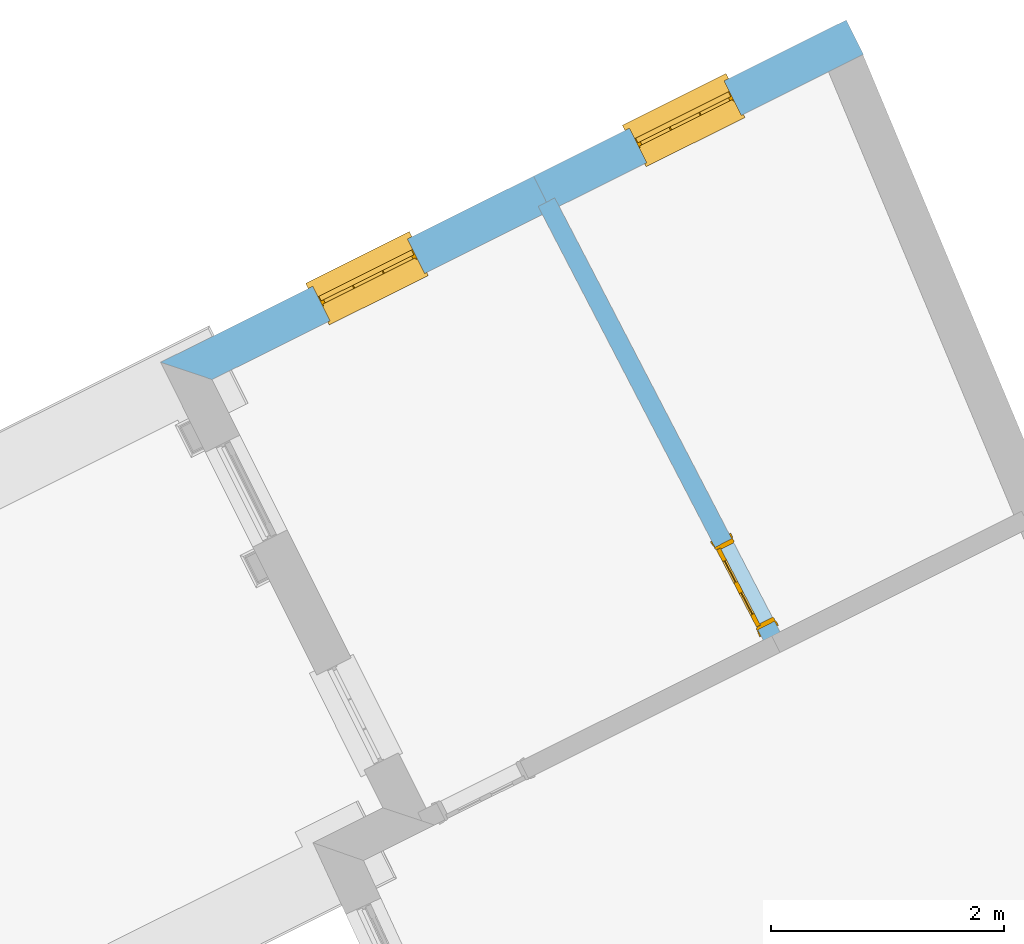
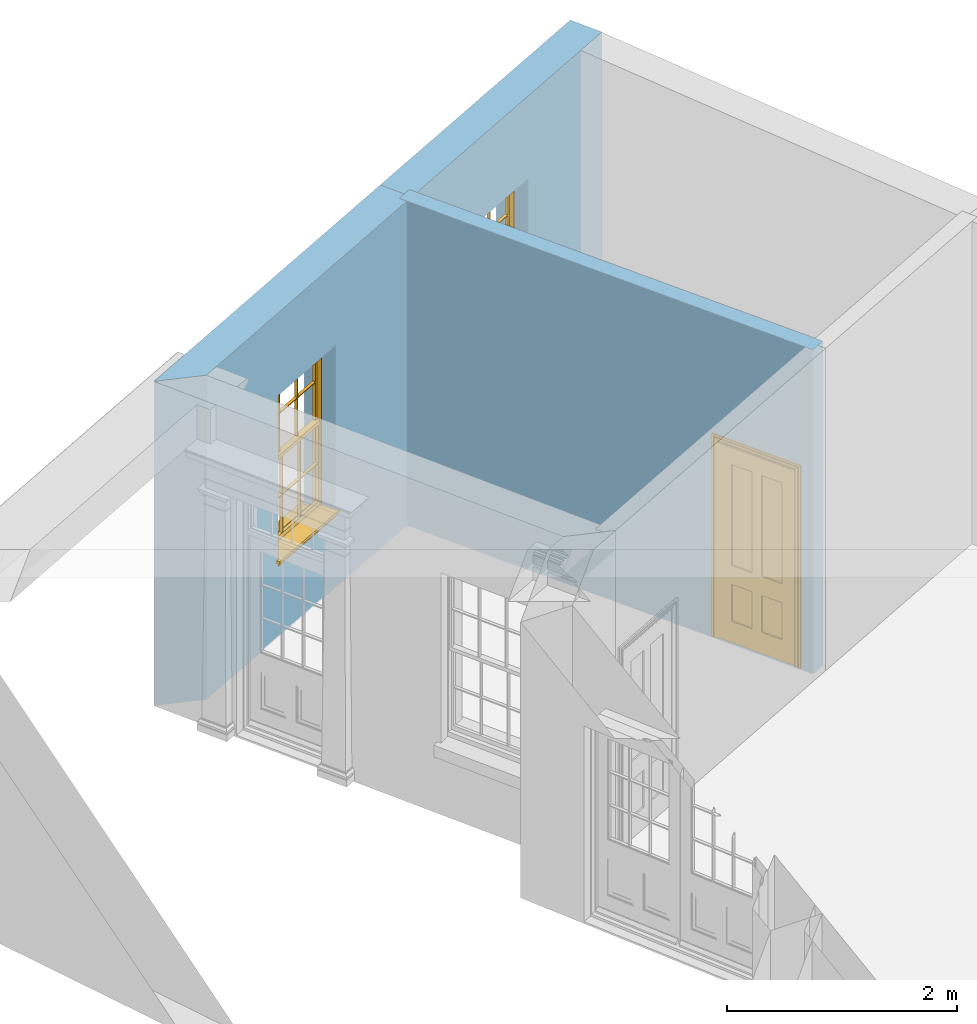
# One storey, part 9 of 10: 2 windows, 1 door, 3 openings, plus 3 elements that do not belong to this part.
"""IFC2X3 building model written with IfcOpenShell, lengths in metres."""

from ifc_helpers import new_model, si_unit, frame, origin, place, context, subcontext, project, spatial, polyline, outline, extrude, faceted_brep, material, layer, layer_set, layer_usage, element, fill, save


model = new_model("IFC2X3")

# Units and contexts
model_context = context("Model", 3, world=origin())
body_context = subcontext(model_context, "Body", "Model", "MODEL_VIEW")
ifc_project = project(units=[si_unit("PLANEANGLEUNIT", "RADIAN"), si_unit("MASSUNIT", "GRAM", prefix="KILO"), si_unit("FORCEUNIT", "NEWTON", prefix="KILO"), si_unit("LENGTHUNIT", "METRE")], contexts=[model_context])

# Site, building, storey
site_placement = place(None, origin())
site = spatial("IfcSite", under=ifc_project, at=site_placement, CompositionType="ELEMENT")
building_placement = place(None, origin())
building = spatial("IfcBuilding", under=site, at=building_placement, Name="Building plot-8", CompositionType="ELEMENT")
storey_placement = place(None, origin())
storey = spatial("IfcBuildingStorey", under=building, at=storey_placement, Name="Floor 0", CompositionType="ELEMENT", Elevation=0.0)

# Wall, opening, window
ifc_material_1 = material(Name="Masonry")
ifc_layer_1 = layer(ifc_material_1, 0.33, ventilated=False)
ifc_layer_set_1 = layer_set([ifc_layer_1], Name="My Wall")
ifc_layer_usage_1 = layer_usage(ifc_layer_set_1, "AXIS2", "NEGATIVE", 0.08)
wall_1_placement = place(storey_placement, origin())
wall_1 = element("IfcWallStandardCase", 1, at=wall_1_placement, inside=storey, material=ifc_layer_usage_1, Name="exterior", context=body_context, shape_type="SweptSolid", body=[
    extrude(outline(polyline([(28.1976396877446, 19.9353489269842), (28.0502378466283, 20.230599155156), (25.3643689149095, 18.889695786567), (25.5117707560258, 18.5944455583952), (28.1976396877446, 19.9353489269842)])), origin(), (0.0, 0.0, 1.0), 3.45),
])
opening_1_placement = place(storey_placement, frame((0.0, 0.0, 0.75)))
opening_1 = element("IfcOpeningElement", 2, at=opening_1_placement, cuts=wall_1, Name="Opening", ObjectType="Opening", context=body_context, shape_type="SweptSolid", body=[
    extrude(outline(polyline([(27.0025536089408, 19.7075493119778), (26.1883787373153, 19.3010775682935), (26.3357805784316, 19.0058273401217), (27.149955450057, 19.4122990838059), (27.0025536089408, 19.7075493119778)])), origin(), (0.0, 0.0, 1.0), 1.82),
])
window_1_placement = place(storey_placement, frame((27.1142216703925, 19.4838748966961, 0.75), z_axis=(0.0, 0.0, 1.0), x_axis=(-0.814174871625433, -0.406471743684243, 0.0)))
window_1 = element("IfcWindow", 3, at=window_1_placement, inside=storey, Name="toilet street window", OverallHeight=1.82, OverallWidth=0.91, context=body_context, shape_type="Brep", held_by="IfcProductRepresentation", body=[
    faceted_brep([(0.033125, -0.105, 0.975209), (0.01, -0.105, 0.975209), (0.033125, -0.105, 1.376042), (0.876875, -0.105, 0.975209), (0.876875, -0.105, 1.376042), (0.9, -0.105, 0.975209), (0.876875, -0.105, 1.386042), (0.876875, -0.105, 1.786875), (0.9, -0.105, 1.81), (0.033125, -0.105, 1.786875), (0.033125, -0.105, 1.386042), (0.01, -0.105, 1.81), (0.876875, -0.135, 1.376042), (0.876875, -0.135, 0.975209), (0.9, -0.135, 0.937083), (0.033125, -0.135, 1.786875), (0.01, -0.135, 1.81), (0.033125, -0.135, 1.386042), (0.01, -0.135, 0.937083), (0.033125, -0.135, 0.975209), (0.033125, -0.135, 1.376042), (0.876875, -0.135, 1.786875), (0.876875, -0.135, 1.386042), (0.9, -0.135, 1.81), (0.033125, -0.105, 0.937083), (0.01, -0.105, 0.937083), (0.033125, -0.105, 0.53625), (0.876875, -0.105, 0.937083), (0.876875, -0.105, 0.53625), (0.9, -0.105, 0.937083), (0.876875, -0.105, 0.52625), (0.876875, -0.105, 0.125417), (0.9, -0.105, 0.077167), (0.033125, -0.105, 0.125417), (0.033125, -0.105, 0.52625), (0.01, -0.105, 0.077167), (-0.0425, -0.25, 0.01), (-0.0425, -0.3, 0.001667), (0.0, -0.25, 0.01), (0.9525, -0.25, 0.01), (0.91, -0.25, 0.01), (0.9525, -0.3, 0.001667), (-0.02, 0.08, 0.077167), (0.0, 0.08, 0.077167), (-0.02, 0.11, 0.077167), (0.0, -0.06, 0.077167), (0.01, -0.06, 0.077167), (0.91, -0.06, 0.077167), (0.91, 0.08, 0.077167), (0.9, -0.06, 0.077167), (0.93, 0.08, 0.077167), (0.93, 0.11, 0.077167), (0.01, -0.075, 0.975209), (0.9, -0.075, 0.975209), (0.876875, -0.075, 0.125417), (0.876875, -0.075, 0.52625), (0.9, -0.075, 0.077167), (0.876875, -0.075, 0.53625), (0.876875, -0.075, 0.937083), (0.033125, -0.075, 0.125417), (0.01, -0.075, 0.077167), (0.033125, -0.075, 0.52625), (0.033125, -0.075, 0.937083), (0.033125, -0.075, 0.53625), (-0.02, 0.08, 0.052167), (-0.02, 0.11, 0.052167), (0.93, 0.11, 0.052167), (0.93, 0.08, 0.052167), (0.91, 0.08, 0.052167), (0.0, 0.08, 0.052167), (0.91, -0.15, 0.026667), (0.0, -0.15, 0.026667), (-0.0425, -0.3, -0.123333), (0.9525, -0.3, -0.123333), (-0.0425, -0.25, -0.123333), (0.9525, -0.25, -0.123333), (0.01, -0.06, 1.81), (0.9, -0.06, 1.81), (0.0, -0.06, 1.82), (0.91, -0.06, 1.82), (0.01, -0.15, 0.077167), (0.9, -0.15, 0.077167), (0.592292, -0.105, 0.125417), (0.592292, -0.075, 0.125417), (0.317708, -0.075, 0.125417), (0.317708, -0.105, 0.125417), (0.592292, -0.105, 0.53625), (0.317708, -0.105, 0.53625), (0.317708, -0.105, 0.52625), (0.592292, -0.105, 0.52625), (0.592292, -0.075, 0.53625), (0.317708, -0.075, 0.53625), (0.592292, -0.135, 1.386042), (0.592292, -0.105, 1.386042), (0.317708, -0.105, 1.386042), (0.317708, -0.135, 1.386042), (0.317708, -0.135, 1.376042), (0.592292, -0.135, 1.376042), (0.317708, -0.105, 1.376042), (0.592292, -0.105, 1.376042), (0.602292, -0.135, 1.376042), (0.592292, -0.135, 0.975209), (0.602292, -0.135, 0.975209), (0.602292, -0.105, 0.975209), (0.592292, -0.105, 0.975209), (0.602292, -0.105, 1.376042), (0.602292, -0.075, 0.53625), (0.602292, -0.105, 0.53625), (0.317708, -0.075, 0.52625), (0.307708, -0.075, 0.125417), (0.307708, -0.075, 0.52625), (0.602292, -0.075, 0.52625), (0.602292, -0.075, 0.125417), (0.592292, -0.075, 0.52625), (0.307708, -0.075, 0.53625), (0.317708, -0.075, 0.937083), (0.307708, -0.075, 0.937083), (0.602292, -0.075, 0.937083), (0.592292, -0.075, 0.937083), (0.307708, -0.105, 0.52625), (0.307708, -0.105, 0.125417), (0.307708, -0.105, 0.53625), (0.307708, -0.105, 0.937083), (0.592292, -0.105, 0.937083), (0.317708, -0.105, 0.937083), (0.602292, -0.105, 0.937083), (0.602292, -0.105, 0.52625), (0.602292, -0.105, 0.125417), (0.307708, -0.135, 1.386042), (0.307708, -0.135, 1.376042), (0.307708, -0.135, 0.975209), (0.317708, -0.135, 0.975209), (0.317708, -0.135, 1.786875), (0.307708, -0.135, 1.786875), (0.602292, -0.135, 1.786875), (0.592292, -0.135, 1.786875), (0.602292, -0.135, 1.386042), (0.602292, -0.105, 1.386042), (0.307708, -0.105, 1.386042), (0.307708, -0.105, 1.786875), (0.317708, -0.105, 1.786875), (0.592292, -0.105, 1.786875), (0.602292, -0.105, 1.786875), (0.307708, -0.105, 1.376042), (0.317708, -0.105, 0.975209), (0.307708, -0.105, 0.975209), (0.91, -0.15, 1.82), (0.9, -0.15, 1.81), (0.01, -0.15, 1.81), (0.0, -0.15, 1.82), (0.91, -0.25, 0.0), (0.0, -0.25, 0.0), (0.91, 0.08, 0.0), (0.0, 0.08, 0.0)], [[[0, 1, 2]], [[3, 4, 5]], [[6, 7, 8]], [[9, 10, 11]], [[12, 13, 14]], [[15, 16, 17]], [[18, 19, 20]], [[21, 22, 23]], [[24, 25, 26]], [[27, 28, 29]], [[30, 31, 32]], [[33, 34, 35]], [[14, 27, 29]], [[25, 24, 18]], [[36, 37, 38]], [[39, 40, 41]], [[42, 43, 44]], [[45, 46, 43]], [[47, 48, 49]], [[50, 51, 48]], [[1, 0, 52]], [[5, 53, 3]], [[54, 55, 56]], [[57, 58, 53]], [[59, 60, 61]], [[62, 63, 52]], [[48, 43, 46, 49]], [[51, 44, 43, 48]], [[64, 42, 44, 65]], [[65, 44, 51, 66]], [[66, 51, 50, 67]], [[65, 66, 68, 69]], [[60, 56, 49, 46]], [[70, 71, 38, 40]], [[37, 41, 40, 38]], [[37, 72, 73, 41]], [[74, 75, 73, 72]], [[8, 11, 76, 77]], [[76, 78, 79, 77]], [[32, 35, 80, 81]], [[81, 80, 71, 70]], [[82, 83, 84, 85]], [[86, 87, 88, 89]], [[86, 90, 91, 87]], [[92, 93, 94, 95]], [[92, 95, 96, 97]], [[96, 98, 99, 97]], [[100, 97, 101, 102]], [[103, 104, 99, 105]], [[97, 99, 104, 101]], [[102, 103, 105, 100]], [[28, 57, 106, 107]], [[108, 84, 109, 110]], [[111, 112, 83, 113]], [[114, 110, 61, 63]], [[90, 113, 108, 91]], [[115, 91, 114, 116]], [[117, 106, 90, 118]], [[111, 106, 57, 55]], [[119, 110, 109, 120]], [[34, 61, 110, 119]], [[89, 113, 83, 82]], [[88, 108, 113, 89]], [[85, 84, 108, 88]], [[121, 114, 63, 26]], [[122, 116, 114, 121]], [[123, 118, 90, 86]], [[87, 91, 115, 124]], [[107, 106, 117, 125]], [[126, 111, 55, 30]], [[127, 112, 111, 126]], [[126, 30, 28, 107]], [[88, 119, 120, 85]], [[126, 89, 82, 127]], [[125, 123, 86, 107]], [[121, 26, 34, 119]], [[124, 122, 121, 87]], [[128, 17, 20, 129]], [[96, 129, 130, 131]], [[132, 133, 128, 95]], [[134, 135, 92, 136]], [[100, 12, 22, 136]], [[137, 6, 4, 105]], [[94, 138, 139, 140]], [[137, 93, 141, 142]], [[99, 98, 94, 93]], [[143, 2, 10, 138]], [[144, 145, 143, 98]], [[129, 143, 145, 130]], [[20, 2, 143, 129]], [[131, 144, 98, 96]], [[128, 138, 10, 17]], [[133, 139, 138, 128]], [[135, 141, 93, 92]], [[95, 94, 140, 132]], [[22, 6, 137, 136]], [[136, 137, 142, 134]], [[100, 105, 4, 12]], [[107, 86, 89, 126]], [[106, 111, 113, 90]], [[91, 108, 110, 114]], [[87, 121, 119, 88]], [[97, 100, 136, 92]], [[129, 96, 95, 128]], [[98, 143, 138, 94]], [[105, 99, 93, 137]], [[131, 101, 104, 144]], [[124, 115, 118, 123]], [[132, 140, 141, 135]], [[120, 109, 59, 33]], [[15, 9, 139, 133]], [[134, 142, 7, 21]], [[31, 54, 112, 127]], [[36, 74, 72, 37]], [[39, 41, 73, 75]], [[18, 14, 101, 131]], [[23, 16, 132, 135]], [[83, 56, 60, 84]], [[52, 53, 118, 115]], [[53, 52, 144, 104]], [[11, 8, 141, 140]], [[14, 18, 124, 123]], [[2, 1, 11, 10]], [[8, 5, 4, 6]], [[57, 53, 56, 55]], [[60, 52, 63, 61]], [[26, 25, 35, 34]], [[32, 29, 28, 30]], [[14, 23, 22, 12]], [[18, 20, 17, 16]], [[19, 0, 2, 20]], [[17, 10, 9, 15]], [[12, 4, 3, 13]], [[21, 7, 6, 22]], [[27, 58, 57, 28]], [[30, 55, 54, 31]], [[33, 59, 61, 34]], [[26, 63, 62, 24]], [[5, 8, 77, 53]], [[76, 11, 1, 52]], [[46, 45, 78, 76]], [[49, 77, 79, 47]], [[70, 146, 147, 81]], [[71, 80, 148, 149]], [[19, 130, 145, 0]], [[102, 13, 3, 103]], [[116, 122, 24, 62]], [[29, 32, 81, 14]], [[80, 35, 25, 18]], [[60, 46, 76, 52]], [[77, 49, 56, 53]], [[23, 14, 81, 147]], [[16, 148, 80, 18]], [[35, 85, 120]], [[120, 33, 35]], [[127, 82, 32]], [[32, 31, 127]], [[32, 82, 85, 35]], [[102, 101, 14]], [[14, 13, 102]], [[18, 131, 130]], [[130, 19, 18]], [[134, 21, 23]], [[23, 135, 134]], [[16, 15, 133]], [[133, 132, 16]], [[11, 140, 139]], [[139, 9, 11]], [[142, 141, 8]], [[8, 7, 142]], [[23, 147, 148, 16]], [[146, 149, 148, 147]], [[52, 115, 116]], [[116, 62, 52]], [[118, 53, 117]], [[58, 117, 53]], [[27, 125, 117, 58]], [[56, 83, 112]], [[112, 54, 56]], [[109, 84, 60]], [[60, 59, 109]], [[125, 27, 14]], [[14, 123, 125]], [[122, 124, 18]], [[18, 24, 122]], [[145, 144, 52]], [[52, 0, 145]], [[103, 3, 53]], [[53, 104, 103]], [[79, 78, 149, 146]], [[78, 45, 71, 149]], [[146, 70, 47, 79]], [[150, 75, 74, 151]], [[68, 66, 67]], [[48, 68, 67, 50]], [[69, 64, 65]], [[42, 64, 69, 43]], [[69, 68, 152, 153]], [[70, 68, 48, 47]], [[150, 152, 68, 70]], [[43, 69, 71, 45]], [[69, 153, 151, 71]], [[152, 150, 151, 153]], [[38, 151, 74, 36]], [[71, 151, 38]], [[39, 75, 150, 40]], [[40, 150, 70]]]),
])
fill(opening_1, window_1)

wall_2_placement = place(storey_placement, origin())
wall_2 = element("IfcWallStandardCase", 4, at=wall_2_placement, inside=storey, material=ifc_layer_usage_1, Name="exterior", context=body_context, shape_type="SweptSolid", body=[
    extrude(outline(polyline([(25.5117707560258, 18.5944455583952), (25.3643689149095, 18.889695786567), (22.162338538902, 17.2911020254168), (22.6049906081901, 17.1432536383612), (25.5117707560258, 18.5944455583952)])), origin(), (0.0, 0.0, 1.0), 3.45),
])
opening_2_placement = place(storey_placement, frame((0.0, 0.0, 0.75)))
opening_2 = element("IfcOpeningElement", 5, at=opening_2_placement, cuts=wall_2, Name="Opening", ObjectType="Opening", context=body_context, shape_type="SweptSolid", body=[
    extrude(outline(polyline([(24.2822783703593, 18.3494688085599), (23.4681034987339, 17.9429970648756), (23.6155053398501, 17.6477468367038), (24.4296802114756, 18.054218580388), (24.2822783703593, 18.3494688085599)])), origin(), (0.0, 0.0, 1.0), 1.82),
])
window_2_placement = place(storey_placement, frame((24.393946431811, 18.1257943932782, 0.75), z_axis=(0.0, 0.0, 1.0), x_axis=(-0.814174871625433, -0.406471743684246, 0.0)))
window_2 = element("IfcWindow", 6, at=window_2_placement, inside=storey, Name="circulation street window", OverallHeight=1.82, OverallWidth=0.91, context=body_context, shape_type="Brep", held_by="IfcProductRepresentation", body=[
    faceted_brep([(0.033125, -0.105, 0.975209), (0.01, -0.105, 0.975209), (0.033125, -0.105, 1.376042), (0.876875, -0.105, 0.975209), (0.876875, -0.105, 1.376042), (0.9, -0.105, 0.975209), (0.876875, -0.105, 1.386042), (0.876875, -0.105, 1.786875), (0.9, -0.105, 1.81), (0.033125, -0.105, 1.786875), (0.033125, -0.105, 1.386042), (0.01, -0.105, 1.81), (0.876875, -0.135, 1.376042), (0.876875, -0.135, 0.975209), (0.9, -0.135, 0.937083), (0.033125, -0.135, 1.786875), (0.01, -0.135, 1.81), (0.033125, -0.135, 1.386042), (0.01, -0.135, 0.937083), (0.033125, -0.135, 0.975209), (0.033125, -0.135, 1.376042), (0.876875, -0.135, 1.786875), (0.876875, -0.135, 1.386042), (0.9, -0.135, 1.81), (0.033125, -0.105, 0.937083), (0.01, -0.105, 0.937083), (0.033125, -0.105, 0.53625), (0.876875, -0.105, 0.937083), (0.876875, -0.105, 0.53625), (0.9, -0.105, 0.937083), (0.876875, -0.105, 0.52625), (0.876875, -0.105, 0.125417), (0.9, -0.105, 0.077167), (0.033125, -0.105, 0.125417), (0.033125, -0.105, 0.52625), (0.01, -0.105, 0.077167), (-0.0425, -0.25, 0.01), (-0.0425, -0.3, 0.001667), (0.0, -0.25, 0.01), (0.9525, -0.25, 0.01), (0.91, -0.25, 0.01), (0.9525, -0.3, 0.001667), (-0.02, 0.08, 0.077167), (0.0, 0.08, 0.077167), (-0.02, 0.11, 0.077167), (0.0, -0.06, 0.077167), (0.01, -0.06, 0.077167), (0.91, -0.06, 0.077167), (0.91, 0.08, 0.077167), (0.9, -0.06, 0.077167), (0.93, 0.08, 0.077167), (0.93, 0.11, 0.077167), (0.01, -0.075, 0.975209), (0.9, -0.075, 0.975209), (0.876875, -0.075, 0.125417), (0.876875, -0.075, 0.52625), (0.9, -0.075, 0.077167), (0.876875, -0.075, 0.53625), (0.876875, -0.075, 0.937083), (0.033125, -0.075, 0.125417), (0.01, -0.075, 0.077167), (0.033125, -0.075, 0.52625), (0.033125, -0.075, 0.937083), (0.033125, -0.075, 0.53625), (-0.02, 0.08, 0.052167), (-0.02, 0.11, 0.052167), (0.93, 0.11, 0.052167), (0.93, 0.08, 0.052167), (0.91, 0.08, 0.052167), (0.0, 0.08, 0.052167), (0.91, -0.15, 0.026667), (0.0, -0.15, 0.026667), (-0.0425, -0.3, -0.123333), (0.9525, -0.3, -0.123333), (-0.0425, -0.25, -0.123333), (0.9525, -0.25, -0.123333), (0.01, -0.06, 1.81), (0.9, -0.06, 1.81), (0.0, -0.06, 1.82), (0.91, -0.06, 1.82), (0.01, -0.15, 0.077167), (0.9, -0.15, 0.077167), (0.592292, -0.105, 0.125417), (0.592292, -0.075, 0.125417), (0.317708, -0.075, 0.125417), (0.317708, -0.105, 0.125417), (0.592292, -0.105, 0.53625), (0.317708, -0.105, 0.53625), (0.317708, -0.105, 0.52625), (0.592292, -0.105, 0.52625), (0.592292, -0.075, 0.53625), (0.317708, -0.075, 0.53625), (0.592292, -0.135, 1.386042), (0.592292, -0.105, 1.386042), (0.317708, -0.105, 1.386042), (0.317708, -0.135, 1.386042), (0.317708, -0.135, 1.376042), (0.592292, -0.135, 1.376042), (0.317708, -0.105, 1.376042), (0.592292, -0.105, 1.376042), (0.602292, -0.135, 1.376042), (0.592292, -0.135, 0.975209), (0.602292, -0.135, 0.975209), (0.602292, -0.105, 0.975209), (0.592292, -0.105, 0.975209), (0.602292, -0.105, 1.376042), (0.602292, -0.075, 0.53625), (0.602292, -0.105, 0.53625), (0.317708, -0.075, 0.52625), (0.307708, -0.075, 0.125417), (0.307708, -0.075, 0.52625), (0.602292, -0.075, 0.52625), (0.602292, -0.075, 0.125417), (0.592292, -0.075, 0.52625), (0.307708, -0.075, 0.53625), (0.317708, -0.075, 0.937083), (0.307708, -0.075, 0.937083), (0.602292, -0.075, 0.937083), (0.592292, -0.075, 0.937083), (0.307708, -0.105, 0.52625), (0.307708, -0.105, 0.125417), (0.307708, -0.105, 0.53625), (0.307708, -0.105, 0.937083), (0.592292, -0.105, 0.937083), (0.317708, -0.105, 0.937083), (0.602292, -0.105, 0.937083), (0.602292, -0.105, 0.52625), (0.602292, -0.105, 0.125417), (0.307708, -0.135, 1.386042), (0.307708, -0.135, 1.376042), (0.307708, -0.135, 0.975209), (0.317708, -0.135, 0.975209), (0.317708, -0.135, 1.786875), (0.307708, -0.135, 1.786875), (0.602292, -0.135, 1.786875), (0.592292, -0.135, 1.786875), (0.602292, -0.135, 1.386042), (0.602292, -0.105, 1.386042), (0.307708, -0.105, 1.386042), (0.307708, -0.105, 1.786875), (0.317708, -0.105, 1.786875), (0.592292, -0.105, 1.786875), (0.602292, -0.105, 1.786875), (0.307708, -0.105, 1.376042), (0.317708, -0.105, 0.975209), (0.307708, -0.105, 0.975209), (0.91, -0.15, 1.82), (0.9, -0.15, 1.81), (0.01, -0.15, 1.81), (0.0, -0.15, 1.82), (0.91, -0.25, 0.0), (0.0, -0.25, 0.0), (0.91, 0.08, 0.0), (0.0, 0.08, 0.0)], [[[0, 1, 2]], [[3, 4, 5]], [[6, 7, 8]], [[9, 10, 11]], [[12, 13, 14]], [[15, 16, 17]], [[18, 19, 20]], [[21, 22, 23]], [[24, 25, 26]], [[27, 28, 29]], [[30, 31, 32]], [[33, 34, 35]], [[14, 27, 29]], [[25, 24, 18]], [[36, 37, 38]], [[39, 40, 41]], [[42, 43, 44]], [[45, 46, 43]], [[47, 48, 49]], [[50, 51, 48]], [[1, 0, 52]], [[5, 53, 3]], [[54, 55, 56]], [[57, 58, 53]], [[59, 60, 61]], [[62, 63, 52]], [[48, 43, 46, 49]], [[51, 44, 43, 48]], [[64, 42, 44, 65]], [[65, 44, 51, 66]], [[66, 51, 50, 67]], [[65, 66, 68, 69]], [[60, 56, 49, 46]], [[70, 71, 38, 40]], [[37, 41, 40, 38]], [[37, 72, 73, 41]], [[74, 75, 73, 72]], [[8, 11, 76, 77]], [[76, 78, 79, 77]], [[32, 35, 80, 81]], [[81, 80, 71, 70]], [[82, 83, 84, 85]], [[86, 87, 88, 89]], [[86, 90, 91, 87]], [[92, 93, 94, 95]], [[92, 95, 96, 97]], [[96, 98, 99, 97]], [[100, 97, 101, 102]], [[103, 104, 99, 105]], [[97, 99, 104, 101]], [[102, 103, 105, 100]], [[28, 57, 106, 107]], [[108, 84, 109, 110]], [[111, 112, 83, 113]], [[114, 110, 61, 63]], [[90, 113, 108, 91]], [[115, 91, 114, 116]], [[117, 106, 90, 118]], [[111, 106, 57, 55]], [[119, 110, 109, 120]], [[34, 61, 110, 119]], [[89, 113, 83, 82]], [[88, 108, 113, 89]], [[85, 84, 108, 88]], [[121, 114, 63, 26]], [[122, 116, 114, 121]], [[123, 118, 90, 86]], [[87, 91, 115, 124]], [[107, 106, 117, 125]], [[126, 111, 55, 30]], [[127, 112, 111, 126]], [[126, 30, 28, 107]], [[88, 119, 120, 85]], [[126, 89, 82, 127]], [[125, 123, 86, 107]], [[121, 26, 34, 119]], [[124, 122, 121, 87]], [[128, 17, 20, 129]], [[96, 129, 130, 131]], [[132, 133, 128, 95]], [[134, 135, 92, 136]], [[100, 12, 22, 136]], [[137, 6, 4, 105]], [[94, 138, 139, 140]], [[137, 93, 141, 142]], [[99, 98, 94, 93]], [[143, 2, 10, 138]], [[144, 145, 143, 98]], [[129, 143, 145, 130]], [[20, 2, 143, 129]], [[131, 144, 98, 96]], [[128, 138, 10, 17]], [[133, 139, 138, 128]], [[135, 141, 93, 92]], [[95, 94, 140, 132]], [[22, 6, 137, 136]], [[136, 137, 142, 134]], [[100, 105, 4, 12]], [[107, 86, 89, 126]], [[106, 111, 113, 90]], [[91, 108, 110, 114]], [[87, 121, 119, 88]], [[97, 100, 136, 92]], [[129, 96, 95, 128]], [[98, 143, 138, 94]], [[105, 99, 93, 137]], [[131, 101, 104, 144]], [[124, 115, 118, 123]], [[132, 140, 141, 135]], [[120, 109, 59, 33]], [[15, 9, 139, 133]], [[134, 142, 7, 21]], [[31, 54, 112, 127]], [[36, 74, 72, 37]], [[39, 41, 73, 75]], [[18, 14, 101, 131]], [[23, 16, 132, 135]], [[83, 56, 60, 84]], [[52, 53, 118, 115]], [[53, 52, 144, 104]], [[11, 8, 141, 140]], [[14, 18, 124, 123]], [[2, 1, 11, 10]], [[8, 5, 4, 6]], [[57, 53, 56, 55]], [[60, 52, 63, 61]], [[26, 25, 35, 34]], [[32, 29, 28, 30]], [[14, 23, 22, 12]], [[18, 20, 17, 16]], [[19, 0, 2, 20]], [[17, 10, 9, 15]], [[12, 4, 3, 13]], [[21, 7, 6, 22]], [[27, 58, 57, 28]], [[30, 55, 54, 31]], [[33, 59, 61, 34]], [[26, 63, 62, 24]], [[5, 8, 77, 53]], [[76, 11, 1, 52]], [[46, 45, 78, 76]], [[49, 77, 79, 47]], [[70, 146, 147, 81]], [[71, 80, 148, 149]], [[19, 130, 145, 0]], [[102, 13, 3, 103]], [[116, 122, 24, 62]], [[29, 32, 81, 14]], [[80, 35, 25, 18]], [[60, 46, 76, 52]], [[77, 49, 56, 53]], [[23, 14, 81, 147]], [[16, 148, 80, 18]], [[35, 85, 120]], [[120, 33, 35]], [[127, 82, 32]], [[32, 31, 127]], [[32, 82, 85, 35]], [[102, 101, 14]], [[14, 13, 102]], [[18, 131, 130]], [[130, 19, 18]], [[134, 21, 23]], [[23, 135, 134]], [[16, 15, 133]], [[133, 132, 16]], [[11, 140, 139]], [[139, 9, 11]], [[142, 141, 8]], [[8, 7, 142]], [[23, 147, 148, 16]], [[146, 149, 148, 147]], [[52, 115, 116]], [[116, 62, 52]], [[118, 53, 117]], [[58, 117, 53]], [[27, 125, 117, 58]], [[56, 83, 112]], [[112, 54, 56]], [[109, 84, 60]], [[60, 59, 109]], [[125, 27, 14]], [[14, 123, 125]], [[122, 124, 18]], [[18, 24, 122]], [[145, 144, 52]], [[52, 0, 145]], [[103, 3, 53]], [[53, 104, 103]], [[79, 78, 149, 146]], [[78, 45, 71, 149]], [[146, 70, 47, 79]], [[150, 75, 74, 151]], [[68, 66, 67]], [[48, 68, 67, 50]], [[69, 64, 65]], [[42, 64, 69, 43]], [[69, 68, 152, 153]], [[70, 68, 48, 47]], [[150, 152, 68, 70]], [[43, 69, 71, 45]], [[69, 153, 151, 71]], [[152, 150, 151, 153]], [[38, 151, 74, 36]], [[71, 151, 38]], [[39, 75, 150, 40]], [[40, 150, 70]]]),
])
fill(opening_2, window_2)

# Wall, opening, door
ifc_material_2 = material(Name="Masonry")
ifc_layer_2 = layer(ifc_material_2, 0.16, ventilated=False)
ifc_layer_set_2 = layer_set([ifc_layer_2], Name="My Wall")
ifc_layer_usage_2 = layer_usage(ifc_layer_set_2, "AXIS2", "NEGATIVE", 0.08)
wall_3_placement = place(storey_placement, origin())
wall_3 = element("IfcWallStandardCase", 7, at=wall_3_placement, inside=storey, material=ifc_layer_usage_2, Name="interior", context=body_context, shape_type="SweptSolid", body=[
    extrude(outline(polyline([(27.374973605375, 14.8336573682362), (27.5169852698664, 14.9073641328402), (25.5470428086069, 18.7028747535873), (25.4050311441155, 18.6291679889833), (27.374973605375, 14.8336573682362)])), origin(), (0.0, 0.0, 1.0), 3.45),
])
opening_3_placement = place(storey_placement, frame((0.0, 0.0, 0.02)))
opening_3 = element("IfcOpeningElement", 8, at=opening_3_placement, cuts=wall_3, Name="Opening", ObjectType="Opening", context=body_context, shape_type="SweptSolid", body=[
    extrude(outline(polyline([(27.4340651596868, 15.067127255393), (27.0655313366665, 15.7771855778497), (26.9235196721751, 15.7034788132456), (27.2920534951955, 14.9934204907889), (27.4340651596868, 15.067127255393)])), origin(), (0.0, 0.0, 1.0), 2.1),
])
door_placement = place(storey_placement, frame((27.3630593274411, 15.030273873091, 0.02), z_axis=(0.0, 0.0, 1.0), x_axis=(-0.368533823020318, 0.710058322456703, 0.0)))
door = element("IfcDoor", 9, at=door_placement, inside=storey, Name="toilet inside door", OverallHeight=2.1, OverallWidth=0.8, context=body_context, shape_type="Brep", held_by="IfcProductRepresentation", body=[
    faceted_brep([(0.773, 0.08, 1.895), (0.66, 0.08, 1.895), (0.66, 0.08, 2.073), (0.773, 0.08, 2.073), (0.773, 0.08, 0.82), (0.66, 0.08, 0.82), (0.45, 0.08, 1.895), (0.45, 0.08, 2.073), (0.773, 0.08, 0.62), (0.66, 0.08, 0.62), (0.66, 0.065, 0.82), (0.66, 0.065, 1.895), (0.45, 0.065, 1.895), (0.35, 0.08, 1.895), (0.35, 0.08, 2.073), (0.773, 0.08, 0.225), (0.66, 0.08, 0.225), (0.45, 0.08, 0.62), (0.45, 0.08, 0.82), (0.45, 0.065, 0.82), (0.35, 0.08, 0.82), (0.14, 0.08, 2.073), (0.14, 0.08, 1.895), (0.773, 0.08, 0.0), (0.66, 0.08, 0.0), (0.66, 0.065, 0.225), (0.66, 0.065, 0.62), (0.45, 0.065, 0.62), (0.35, 0.08, 0.62), (0.35, 0.065, 0.82), (0.35, 0.065, 1.895), (0.14, 0.065, 1.895), (0.027, 0.08, 2.073), (0.027, 0.08, 1.895), (0.773, 0.042, 0.0), (0.66, 0.042, 0.0), (0.45, 0.08, 0.0), (0.45, 0.08, 0.225), (0.45, 0.065, 0.225), (0.35, 0.08, 0.225), (0.14, 0.08, 0.82), (0.14, 0.08, 0.62), (0.14, 0.065, 0.82), (0.027, 0.08, 0.82), (0.773, 0.042, 0.225), (0.66, 0.042, 0.225), (0.45, 0.042, 0.0), (0.35, 0.08, 0.0), (0.35, 0.065, 0.225), (0.35, 0.065, 0.62), (0.14, 0.065, 0.62), (0.027, 0.08, 0.62), (0.773, 0.042, 0.62), (0.66, 0.042, 0.62), (0.45, 0.042, 0.225), (0.35, 0.042, 0.0), (0.14, 0.08, 0.225), (0.14, 0.08, 0.0), (0.14, 0.065, 0.225), (0.027, 0.08, 0.225), (0.773, 0.042, 0.82), (0.66, 0.042, 0.82), (0.66, 0.057, 0.62), (0.66, 0.057, 0.225), (0.45, 0.057, 0.225), (0.35, 0.042, 0.225), (0.14, 0.042, 0.0), (0.027, 0.08, 0.0), (0.773, 0.042, 1.895), (0.66, 0.042, 1.895), (0.45, 0.042, 0.62), (0.45, 0.042, 0.82), (0.45, 0.057, 0.62), (0.35, 0.042, 0.62), (0.14, 0.042, 0.225), (0.027, 0.042, 0.0), (0.773, 0.042, 2.073), (0.66, 0.042, 2.073), (0.66, 0.057, 1.895), (0.66, 0.057, 0.82), (0.45, 0.057, 0.82), (0.35, 0.042, 0.82), (0.35, 0.057, 0.62), (0.35, 0.057, 0.225), (0.14, 0.057, 0.225), (0.027, 0.042, 0.225), (0.45, 0.042, 1.895), (0.45, 0.042, 2.073), (0.45, 0.057, 1.895), (0.35, 0.042, 1.895), (0.14, 0.042, 0.82), (0.14, 0.042, 0.62), (0.14, 0.057, 0.62), (0.027, 0.042, 0.62), (0.35, 0.042, 2.073), (0.35, 0.057, 1.895), (0.35, 0.057, 0.82), (0.14, 0.057, 0.82), (0.027, 0.042, 0.82), (0.14, 0.042, 2.073), (0.14, 0.042, 1.895), (0.14, 0.057, 1.895), (0.027, 0.042, 1.895), (0.027, 0.042, 2.073), (0.02, 0.085, 0.0), (0.005, 0.09, 0.0), (0.005, 0.09, 2.095), (0.02, 0.085, 2.08), (0.02, 0.08, 0.0), (0.0, 0.085, 0.0), (0.0, 0.085, 2.1), (0.795, 0.09, 2.095), (0.78, 0.085, 2.08), (0.02, 0.08, 2.08), (0.0, 0.08, 0.0), (-0.032, 0.095, 0.0), (-0.032, 0.095, 2.132), (0.8, 0.085, 2.1), (0.795, 0.09, 0.0), (0.78, 0.085, 0.0), (0.78, 0.08, 2.08), (0.04, 0.04, 0.0), (0.025, 0.04, 0.0), (0.025, 0.04, 2.075), (0.04, 0.04, 2.06), (-0.04, 0.09, 0.0), (-0.04, 0.09, 2.14), (0.832, 0.095, 2.132), (0.8, 0.085, 0.0), (0.78, 0.08, 0.0), (0.8, 0.08, 0.0), (0.86, 0.08, 0.0), (0.86, 0.08, 2.16), (0.8, 0.08, 2.1), (-0.06, 0.08, 2.16), (0.0, 0.08, 2.1), (-0.06, 0.08, 0.0), (-0.04, 0.095, 0.0), (-0.04, 0.095, 2.14), (0.84, 0.09, 2.14), (0.832, 0.095, 0.0), (0.84, 0.09, 0.0), (0.86, 0.095, 0.0), (0.86, 0.095, 2.16), (-0.06, 0.095, 2.16), (-0.06, 0.095, 0.0), (0.84, 0.095, 0.0), (0.84, 0.095, 2.14), (-0.025, -0.095, 0.0), (-0.025, -0.09, 0.0), (-0.025, -0.09, 2.125), (-0.025, -0.095, 2.125), (-0.017, -0.095, 0.0), (-0.017, -0.095, 2.117), (0.825, -0.09, 2.125), (0.825, -0.095, 2.125), (0.825, -0.095, 0.0), (0.845, -0.095, 0.0), (-0.045, -0.095, 2.145), (-0.045, -0.095, 0.0), (0.845, -0.095, 2.145), (0.015, -0.085, 0.0), (0.015, -0.085, 2.085), (0.817, -0.095, 2.117), (0.825, -0.09, 0.0), (0.845, -0.08, 0.0), (0.845, -0.08, 2.145), (-0.045, -0.08, 2.145), (-0.045, -0.08, 0.0), (0.02, -0.09, 0.0), (0.02, -0.09, 2.08), (0.785, -0.085, 2.085), (0.817, -0.095, 0.0), (0.8, -0.08, 0.0), (0.8, -0.08, 2.1), (0.0, -0.08, 2.1), (0.0, -0.08, 0.0), (0.035, -0.085, 0.0), (0.035, -0.085, 2.065), (0.78, -0.09, 2.08), (0.785, -0.085, 0.0), (0.775, 0.04, 2.075), (0.76, 0.04, 2.06), (0.035, -0.08, 2.065), (0.035, -0.08, 0.0), (0.765, -0.085, 2.065), (0.78, -0.09, 0.0), (0.765, -0.08, 0.0), (0.765, -0.08, 2.065), (0.765, -0.085, 0.0), (0.04, -0.08, 2.06), (0.04, -0.08, 0.0), (0.76, -0.08, 2.06), (0.76, -0.08, 0.0), (0.76, 0.04, 0.0), (0.775, 0.04, 0.0), (0.025, 0.08, 0.0), (0.025, 0.08, 2.075), (0.775, 0.08, 0.0), (0.775, 0.08, 2.075)], [[[0, 1, 2, 3]], [[1, 0, 4, 5]], [[1, 6, 7, 2]], [[8, 9, 5, 4]], [[1, 5, 10, 11]], [[6, 1, 11, 12]], [[6, 13, 14, 7]], [[15, 16, 9, 8]], [[9, 17, 18, 5]], [[5, 18, 19, 10]], [[10, 19, 12, 11]], [[18, 6, 12, 19]], [[18, 20, 13, 6]], [[21, 14, 13, 22]], [[23, 24, 16, 15]], [[9, 16, 25, 26]], [[17, 9, 26, 27]], [[17, 28, 20, 18]], [[13, 20, 29, 30]], [[22, 13, 30, 31]], [[32, 21, 22, 33]], [[34, 35, 24, 23]], [[24, 36, 37, 16]], [[16, 37, 38, 25]], [[25, 38, 27, 26]], [[37, 17, 27, 38]], [[37, 39, 28, 17]], [[40, 20, 28, 41]], [[20, 40, 42, 29]], [[31, 30, 29, 42]], [[40, 22, 31, 42]], [[33, 22, 40, 43]], [[35, 34, 44, 45]], [[35, 46, 36, 24]], [[36, 47, 39, 37]], [[28, 39, 48, 49]], [[41, 28, 49, 50]], [[43, 40, 41, 51]], [[45, 44, 52, 53]], [[46, 35, 45, 54]], [[46, 55, 47, 36]], [[56, 39, 47, 57]], [[39, 56, 58, 48]], [[50, 49, 48, 58]], [[56, 41, 50, 58]], [[51, 41, 56, 59]], [[53, 52, 60, 61]], [[45, 53, 62, 63]], [[54, 45, 63, 64]], [[55, 46, 54, 65]], [[55, 66, 57, 47]], [[59, 56, 57, 67]], [[61, 60, 68, 69]], [[70, 53, 61, 71]], [[53, 70, 72, 62]], [[72, 64, 63, 62]], [[70, 54, 64, 72]], [[65, 54, 70, 73]], [[65, 74, 66, 55]], [[67, 57, 66, 75]], [[69, 68, 76, 77]], [[61, 69, 78, 79]], [[71, 61, 79, 80]], [[73, 70, 71, 81]], [[65, 73, 82, 83]], [[74, 65, 83, 84]], [[74, 85, 75, 66]], [[86, 69, 77, 87]], [[69, 86, 88, 78]], [[88, 80, 79, 78]], [[86, 71, 80, 88]], [[81, 71, 86, 89]], [[73, 81, 90, 91]], [[73, 91, 92, 82]], [[83, 82, 92, 84]], [[91, 74, 84, 92]], [[91, 93, 85, 74]], [[89, 86, 87, 94]], [[81, 89, 95, 96]], [[90, 81, 96, 97]], [[90, 98, 93, 91]], [[94, 99, 100, 89]], [[89, 100, 101, 95]], [[101, 97, 96, 95]], [[100, 90, 97, 101]], [[100, 102, 98, 90]], [[99, 103, 102, 100]], [[32, 103, 99, 21]], [[102, 103, 32, 33]], [[98, 102, 33, 43]], [[21, 99, 94, 14]], [[94, 87, 7, 14]], [[7, 87, 77, 2]], [[76, 3, 2, 77]], [[43, 51, 93, 98]], [[51, 59, 85, 93]], [[67, 75, 85, 59]], [[34, 23, 15, 44]], [[44, 15, 8, 52]], [[52, 8, 4, 60]], [[0, 68, 60, 4]], [[0, 3, 76, 68]], [[104, 105, 106, 107]], [[104, 108, 109, 105]], [[105, 109, 110, 106]], [[107, 106, 111, 112]], [[107, 113, 108, 104]], [[114, 109, 108]], [[109, 115, 116, 110]], [[106, 110, 117, 111]], [[112, 111, 118, 119]], [[113, 107, 112, 120]], [[121, 122, 123, 124]], [[115, 109, 114, 125]], [[115, 125, 126, 116]], [[110, 116, 127, 117]], [[111, 117, 128, 118]], [[118, 128, 129, 119]], [[120, 112, 119, 129]], [[130, 129, 128]], [[130, 131, 132, 133]], [[133, 132, 134, 135]], [[135, 134, 136, 114]], [[136, 125, 114]], [[125, 137, 138, 126]], [[116, 126, 139, 127]], [[117, 127, 140, 128]], [[141, 130, 128, 140]], [[131, 130, 141]], [[131, 142, 143, 132]], [[132, 143, 144, 134]], [[134, 144, 145, 136]], [[137, 125, 136, 145]], [[143, 142, 146]], [[143, 146, 147]], [[137, 145, 144]], [[143, 147, 138]], [[138, 137, 144]], [[143, 138, 144]], [[126, 138, 147, 139]], [[127, 139, 141, 140]], [[142, 131, 141, 146]], [[139, 147, 146, 141]], [[148, 149, 150, 151]], [[149, 152, 153, 150]], [[151, 150, 154, 155]], [[155, 156, 157]], [[158, 159, 148]], [[158, 148, 151]], [[155, 157, 160]], [[158, 151, 155]], [[155, 160, 158]], [[152, 161, 162, 153]], [[150, 153, 163, 154]], [[155, 154, 164, 156]], [[156, 164, 165, 157]], [[157, 165, 166, 160]], [[160, 166, 167, 158]], [[158, 167, 168, 159]], [[161, 169, 170, 162]], [[153, 162, 171, 163]], [[154, 163, 172, 164]], [[165, 164, 173]], [[165, 173, 174, 166]], [[166, 174, 175, 167]], [[167, 175, 176, 168]], [[169, 177, 178, 170]], [[162, 170, 179, 171]], [[163, 171, 180, 172]], [[172, 180, 173, 164]], [[124, 123, 181, 182]], [[183, 178, 177, 184]], [[170, 178, 185, 179]], [[171, 179, 186, 180]], [[187, 173, 180]], [[185, 188, 187, 189]], [[188, 185, 178, 183]], [[179, 185, 189, 186]], [[189, 187, 180, 186]], [[190, 183, 184, 191]], [[192, 188, 183, 190]], [[191, 184, 122, 121]], [[124, 190, 191, 121]], [[193, 187, 188, 192]], [[182, 192, 190, 124]], [[184, 176, 122]], [[194, 195, 187, 193]], [[192, 182, 194, 193]], [[161, 176, 184]], [[114, 108, 122, 176]], [[173, 187, 195]], [[152, 149, 176, 161]], [[169, 161, 184, 177]], [[196, 122, 108]], [[176, 175, 135, 114]], [[173, 195, 129, 130]], [[176, 149, 168]], [[123, 122, 196, 197]], [[196, 108, 113, 197]], [[175, 174, 133, 135]], [[198, 129, 195]], [[133, 174, 173, 130]], [[159, 168, 149, 148]], [[181, 123, 197, 199]], [[197, 113, 120, 199]], [[199, 120, 129, 198]], [[195, 181, 199, 198]], [[195, 194, 182, 181]]]),
])
fill(opening_3, door)

save(model, "model.ifc")
